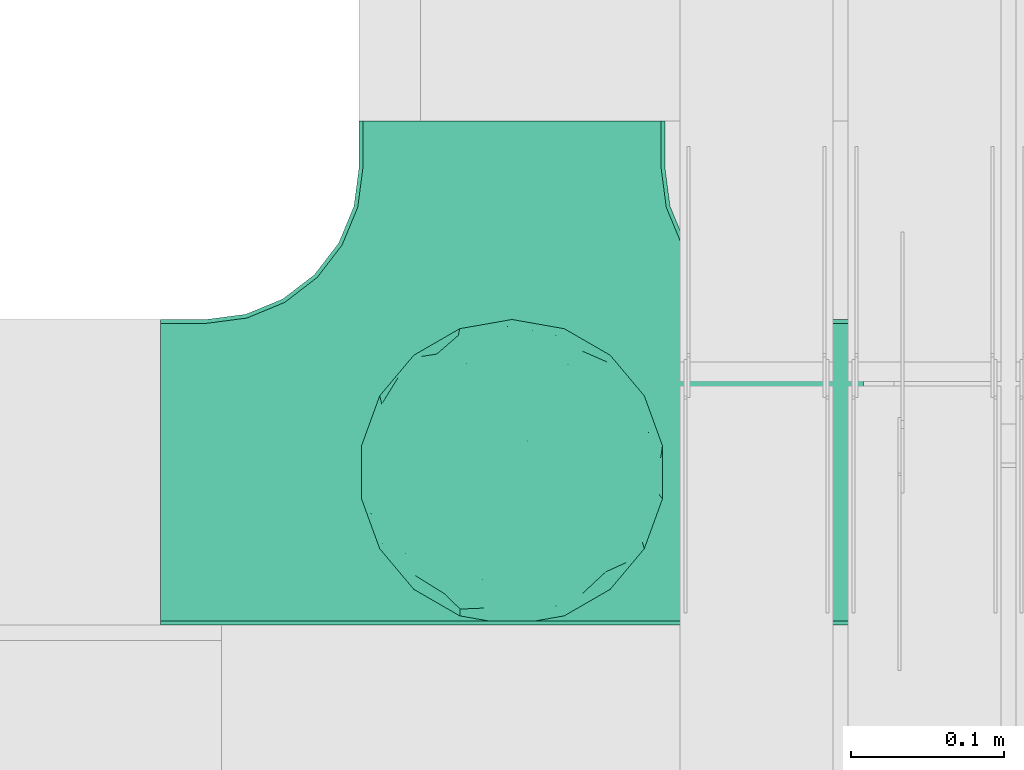
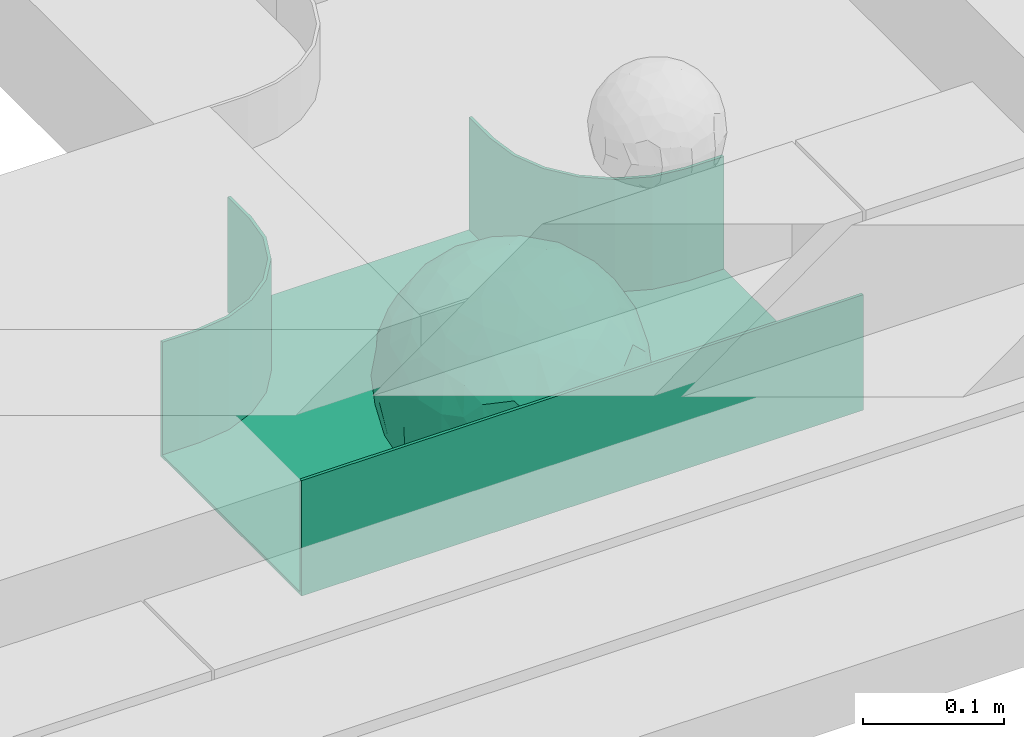
# One storey, part 31 of 32: 1 flow fitting.
"""IFC2X3 building model written with IfcOpenShell, lengths in millimetres."""

from ifc_helpers import new_model, entity, si_unit, converted_unit, derived_unit, direction, frame, origin, place, context, subcontext, project, spatial, faceted_brep, source, transform, mapped, material, material_list, type_object, type_shapes, element, save


model = new_model("IFC2X3")

# Units and contexts
model_context = context("Model", 3, precision=0.01, world=origin(), true_north=direction((6.12303176911189e-17, 1.0)))
body_context = subcontext(model_context, "Body", "Model", "MODEL_VIEW")
ifc_project = project(units=[si_unit("LENGTHUNIT", "METRE", prefix="MILLI"), si_unit("AREAUNIT", "SQUARE_METRE"), si_unit("VOLUMEUNIT", "CUBIC_METRE"), converted_unit("PLANEANGLEUNIT", "DEGREE", entity("IfcRatioMeasure", 0.0174532925199433), si_unit("PLANEANGLEUNIT", "RADIAN"), dimensions=[0, 0, 0, 0, 0, 0, 0]), si_unit("MASSUNIT", "GRAM", prefix="KILO"), derived_unit("MASSDENSITYUNIT", [(si_unit("MASSUNIT", "GRAM", prefix="KILO"), 1), (si_unit("LENGTHUNIT", "METRE"), -3)]), derived_unit("MOMENTOFINERTIAUNIT", [(si_unit("LENGTHUNIT", "METRE"), 4)]), si_unit("TIMEUNIT", "SECOND"), si_unit("FREQUENCYUNIT", "HERTZ"), si_unit("THERMODYNAMICTEMPERATUREUNIT", "DEGREE_CELSIUS"), derived_unit("THERMALTRANSMITTANCEUNIT", [(si_unit("MASSUNIT", "GRAM", prefix="KILO"), 1), (si_unit("THERMODYNAMICTEMPERATUREUNIT", "KELVIN"), -1), (si_unit("TIMEUNIT", "SECOND"), -3)]), derived_unit("VOLUMETRICFLOWRATEUNIT", [(si_unit("LENGTHUNIT", "METRE"), 3), (si_unit("TIMEUNIT", "SECOND"), -1)]), derived_unit("MASSFLOWRATEUNIT", [(si_unit("MASSUNIT", "GRAM", prefix="KILO"), 1), (si_unit("TIMEUNIT", "SECOND"), -1)]), derived_unit("ROTATIONALFREQUENCYUNIT", [(si_unit("TIMEUNIT", "SECOND"), -1)]), si_unit("ELECTRICCURRENTUNIT", "AMPERE"), si_unit("ELECTRICVOLTAGEUNIT", "VOLT"), si_unit("POWERUNIT", "WATT"), si_unit("FORCEUNIT", "NEWTON", prefix="KILO"), si_unit("ILLUMINANCEUNIT", "LUX"), si_unit("LUMINOUSFLUXUNIT", "LUMEN"), si_unit("LUMINOUSINTENSITYUNIT", "CANDELA"), derived_unit("USERDEFINED", [(si_unit("MASSUNIT", "GRAM", prefix="KILO"), -1), (si_unit("LENGTHUNIT", "METRE"), -2), (si_unit("TIMEUNIT", "SECOND"), 3), (si_unit("LUMINOUSFLUXUNIT", "LUMEN"), 1)]), derived_unit("LINEARVELOCITYUNIT", [(si_unit("LENGTHUNIT", "METRE"), 1), (si_unit("TIMEUNIT", "SECOND"), -1)]), si_unit("PRESSUREUNIT", "PASCAL"), derived_unit("USERDEFINED", [(si_unit("LENGTHUNIT", "METRE"), -2), (si_unit("MASSUNIT", "GRAM", prefix="KILO"), 1), (si_unit("TIMEUNIT", "SECOND"), -2)]), derived_unit("LINEARFORCEUNIT", [(si_unit("MASSUNIT", "GRAM", prefix="KILO"), 1), (si_unit("LENGTHUNIT", "METRE"), 1), (si_unit("TIMEUNIT", "SECOND"), -2), (si_unit("LENGTHUNIT", "METRE"), -1)]), derived_unit("PLANARFORCEUNIT", [(si_unit("MASSUNIT", "GRAM", prefix="KILO"), 1), (si_unit("LENGTHUNIT", "METRE"), 1), (si_unit("TIMEUNIT", "SECOND"), -2), (si_unit("LENGTHUNIT", "METRE"), -2)])], contexts=[model_context])

# Site, building, storey
site_placement = place(None, origin())
site = spatial("IfcSite", under=ifc_project, at=site_placement, CompositionType="ELEMENT")
building_placement = place(site_placement, origin())
building = spatial("IfcBuilding", under=site, at=building_placement, CompositionType="ELEMENT")
storey_placement = place(building_placement, frame((0.0, 0.0, 8100.0)))
storey = spatial("IfcBuildingStorey", under=building, at=storey_placement, CompositionType="ELEMENT", Elevation=8100.0)

# Flow fitting
ifc_material_1 = material()
ifc_material_2 = material()
ifc_material_list = material_list([ifc_material_1, ifc_material_2])
cable_carrier_fitting_type = type_object("IfcCableCarrierFittingType", PredefinedType="NOTDEFINED", material=ifc_material_1)
shared_shape = source(origin(), body_context, "Body", "Brep", [
    faceted_brep([(76.48, -37.8, -52.17), (89.29, -26.17, -36.65), (85.27, -46.63, -23.54), (-17.29, -34.78, -92.15), (0.0, -44.16, -89.72), (-24.64, -51.58, -82.05), (76.33, -15.08, -62.82), (55.58, -29.55, -77.71), (-17.1, 96.98, 0.0), (-18.67, 88.89, -41.84), (-33.9, 89.53, -28.9), (-45.46, -10.48, -88.45), (-19.82, 5.04, -97.89), (-23.66, -16.13, -95.81), (92.54, 33.68, 0.0), (85.28, 45.77, -25.16), (86.6, 50.0, 0.0), (49.24, -85.29, 0.0), (62.2, -72.19, -30.32), (64.28, -76.6, 0.0), (97.17, -8.72, -21.95), (90.76, 0.0, -41.98), (96.14, 14.4, -23.44), (98.48, 17.36, 0.0), (98.48, 0.0, 0.0), (79.01, 8.48, -60.71), (76.48, 37.8, -52.17), (87.7, 23.44, -41.95), (29.16, -37.6, -87.95), (20.3, -63.77, -74.31), (-69.62, 53.19, -48.2), (-47.21, 56.75, -67.46), (-61.6, 43.47, -65.69), (29.45, 71.32, -63.61), (47.21, 56.75, -67.46), (30.04, 49.65, -81.44), (-49.67, -77.09, -39.87), (-34.2, -93.97, 0.0), (-49.24, -85.29, 0.0), (61.4, 65.14, -44.57), (74.68, 59.14, -30.41), (61.95, 44.54, -64.64), (28.77, -89.42, -34.29), (34.2, -93.97, 0.0), (25.65, -95.48, 0.0), (17.1, -96.98, 0.0), (-64.28, -76.6, 0.0), (-75.44, -63.3, 0.0), (-74.75, -61.55, -24.99), (7.5, -83.69, -54.22), (36.49, -70.37, -60.97), (-76.48, -37.8, -52.17), (-87.07, -22.49, -43.74), (-79.06, -6.54, -60.88), (63.53, 0.0, -77.22), (-63.53, 0.0, -77.22), (-81.93, 16.04, -55.05), (-98.48, -17.36, 0.0), (-95.57, -17.05, -24.0), (-92.54, -33.68, 0.0), (65.86, 23.41, -71.51), (-19.3, 70.27, -68.49), (-44.33, 79.42, -41.56), (-76.48, 37.8, -52.17), (-45.05, 37.36, -81.09), (-67.2, 22.41, -70.59), (45.89, 15.54, -87.48), (-67.14, -22.46, -70.63), (-97.69, 5.09, -20.78), (-90.76, 0.0, -41.98), (-92.54, 33.68, 0.0), (-92.15, 27.2, -27.72), (28.87, 87.52, -38.83), (7.5, 83.69, -54.22), (1.23, 95.73, -28.9), (3.52, -95.84, -28.34), (-8.55, -98.49, 0.0), (-12.28, -96.15, -24.6), (75.44, 63.3, 0.0), (64.28, 76.6, 0.0), (75.44, -63.3, 0.0), (86.6, -50.0, 0.0), (-75.44, 63.3, 0.0), (-84.89, 46.81, -24.54), (-86.6, 50.0, 0.0), (-65.62, -61.39, -43.88), (-47.21, -56.75, -67.46), (-85.24, -44.68, -27.17), (46.02, 37.17, -80.63), (-63.18, 67.68, -37.79), (-7.15, -67.62, -73.33), (31.54, -5.3, -94.75), (9.85, -20.5, -97.38), (0.0, 13.3, -99.11), (49.35, -11.18, -86.25), (92.54, -33.68, 0.0), (98.48, -17.36, 0.0), (49.24, 85.29, 0.0), (46.4, 79.11, -39.86), (34.2, 93.97, 0.0), (-53.11, 15.12, -83.37), (64.53, -54.17, -53.86), (47.21, -56.75, -67.46), (22.89, 27.57, -93.36), (74.68, -59.14, -30.41), (46.4, -79.11, -39.86), (-15.74, 23.19, -95.99), (2.81, 33.98, -94.01), (9.21, 52.39, -84.68), (9.73, 69.75, -71.0), (17.1, 96.98, 0.0), (-5.62, -90.16, -42.88), (0.0, -100.0, 0.0), (-25.13, -93.37, -25.51), (-25.95, -84.88, -46.06), (-17.1, -96.98, 0.0), (-10.24, -80.78, -58.05), (-31.24, -69.76, -64.48), (-42.19, -33.64, -84.2), (-35.78, 18.55, -91.52), (-61.62, -43.52, -65.64), (-17.34, 40.89, -89.6), (-29.1, 55.69, -77.79), (-10.66, 57.03, -81.45), (-59.77, -75.57, -26.75), (-86.6, -50.0, 0.0), (-98.48, 0.0, 0.0), (-98.48, 17.36, 0.0), (-74.77, 60.7, -26.92), (-64.28, 76.6, 0.0), (-49.24, 85.29, 0.0), (-34.2, 93.97, 0.0), (0.0, 100.0, 0.0), (-76.48, -37.8, 52.17), (-89.29, -26.17, 36.65), (-85.27, -46.63, 23.54), (17.29, -34.78, 92.15), (0.0, -44.16, 89.72), (24.64, -51.58, 82.05), (-76.33, -15.08, 62.82), (-55.58, -29.55, 77.71), (18.67, 88.89, 41.84), (33.9, 89.53, 28.9), (17.34, 40.89, 89.6), (15.74, 23.19, 95.99), (35.78, 18.55, 91.52), (-85.28, 45.77, 25.16), (-62.2, -72.19, 30.32), (-97.17, -8.72, 21.95), (-96.14, 14.4, 23.44), (-79.01, 8.48, 60.71), (-76.48, 37.8, 52.17), (-87.7, 23.44, 41.95), (-29.16, -37.6, 87.95), (-20.3, -63.77, 74.31), (69.62, 53.19, 48.2), (47.21, 56.75, 67.46), (61.6, 43.47, 65.69), (-61.4, 65.14, 44.57), (49.27, -77.35, 39.88), (-74.68, 59.14, 30.41), (-61.95, 44.54, 64.64), (-7.5, -83.69, 54.22), (-36.49, -70.37, 60.97), (-28.77, -89.42, 34.29), (74.74, -61.65, 24.74), (3.0, -95.52, 29.45), (-13.47, -92.75, 34.88), (76.48, -37.8, 52.17), (87.07, -22.49, 43.74), (79.06, -6.54, 60.88), (-63.53, 0.0, 77.22), (63.53, 0.0, 77.22), (81.93, 16.04, 55.05), (95.57, -17.05, 24.0), (-65.86, 23.41, 71.51), (19.3, 70.27, 68.49), (44.33, 79.42, 41.56), (76.48, 37.8, 52.17), (45.05, 37.36, 81.09), (67.2, 22.41, 70.59), (-45.89, 15.54, 87.48), (67.14, -22.46, 70.63), (97.69, 5.09, 20.78), (90.76, 0.0, 41.98), (92.15, 27.2, 27.72), (-28.87, 87.52, 38.83), (-7.5, 83.69, 54.22), (-1.23, 95.73, 28.9), (7.15, -67.62, 73.33), (30.04, -71.02, 63.66), (-90.76, 0.0, 41.98), (84.89, 46.81, 24.54), (65.66, -61.85, 43.17), (47.21, -56.75, 67.46), (85.24, -44.68, 27.17), (-30.04, 49.65, 81.44), (-47.21, 56.75, 67.46), (-46.02, 37.17, 80.63), (63.18, 67.68, 37.79), (-31.54, -5.3, 94.75), (-9.85, -20.5, 97.38), (0.0, 13.3, 99.11), (-49.35, -11.18, 86.25), (-46.4, 79.11, 39.86), (-29.45, 71.32, 63.61), (24.31, -93.79, 24.74), (-64.53, -54.17, 53.86), (-47.21, -56.75, 67.46), (-22.89, 27.57, 93.36), (-46.4, -79.11, 39.86), (-74.68, -59.14, 30.41), (19.82, 5.04, 97.89), (-2.81, 33.98, 94.01), (-9.21, 52.39, 84.68), (-9.73, 69.75, 71.0), (9.65, -80.54, 58.49), (23.47, -86.31, 44.72), (35.11, -89.62, 27.11), (42.19, -33.64, 84.2), (23.66, -16.13, 95.81), (45.46, -10.48, 88.45), (61.62, -43.52, 65.64), (29.1, 55.69, 77.79), (10.66, 57.03, 81.45), (59.35, -75.82, 26.99), (74.77, 60.7, 26.92), (53.11, 15.12, 83.37)], [[[0, 1, 2]], [[3, 4, 5]], [[6, 0, 7]], [[8, 9, 10]], [[11, 12, 13]], [[14, 15, 16]], [[17, 18, 19]], [[20, 21, 22]], [[22, 23, 24]], [[25, 26, 27]], [[4, 28, 29]], [[30, 31, 32]], [[33, 34, 35]], [[36, 37, 38]], [[39, 40, 41]], [[42, 43, 44, 45]], [[46, 47, 48]], [[49, 50, 42]], [[51, 52, 53]], [[54, 25, 6]], [[55, 53, 56]], [[57, 58, 59]], [[26, 25, 60]], [[61, 31, 62]], [[32, 63, 30]], [[64, 65, 32]], [[54, 66, 60]], [[53, 67, 51]], [[58, 68, 69]], [[68, 70, 71]], [[72, 73, 74]], [[75, 76, 77]], [[6, 7, 54]], [[24, 20, 22]], [[78, 40, 79]], [[15, 26, 40]], [[1, 21, 20]], [[80, 2, 81]], [[63, 56, 71]], [[82, 83, 84]], [[36, 85, 86]], [[87, 58, 52]], [[35, 34, 88]], [[62, 31, 89]], [[42, 75, 49]], [[4, 29, 90]], [[91, 92, 93]], [[7, 94, 54]], [[6, 1, 0]], [[95, 81, 2]], [[24, 96, 20]], [[1, 20, 95]], [[1, 95, 2]], [[27, 22, 21]], [[15, 14, 22]], [[25, 27, 21]], [[15, 78, 16]], [[41, 40, 26]], [[40, 78, 15]], [[39, 97, 79]], [[97, 98, 99]], [[40, 39, 79]], [[33, 73, 72]], [[21, 1, 6]], [[25, 54, 60]], [[64, 100, 65]], [[26, 15, 27]], [[6, 25, 21]], [[0, 101, 7]], [[102, 28, 7]], [[92, 91, 28]], [[94, 28, 91]], [[88, 34, 41]], [[54, 94, 66]], [[41, 26, 60]], [[103, 91, 93]], [[88, 41, 60]], [[20, 96, 95]], [[101, 18, 102]], [[104, 80, 19]], [[101, 0, 104]], [[18, 105, 102]], [[43, 42, 105]], [[17, 43, 105]], [[29, 28, 102]], [[28, 4, 92]], [[105, 50, 102]], [[90, 29, 49]], [[88, 60, 66]], [[41, 34, 39]], [[34, 98, 39]], [[97, 39, 98]], [[103, 66, 91]], [[88, 66, 103]], [[12, 106, 93]], [[33, 98, 34]], [[107, 103, 93]], [[35, 103, 108]], [[103, 35, 88]], [[33, 109, 73]], [[109, 35, 108]], [[110, 72, 74]], [[72, 110, 99]], [[98, 33, 72]], [[99, 98, 72]], [[80, 104, 2]], [[0, 2, 104]], [[101, 104, 18]], [[7, 101, 102]], [[19, 18, 104]], [[105, 18, 17]], [[77, 111, 75]], [[75, 45, 112]], [[113, 114, 111]], [[115, 77, 76]], [[36, 114, 37]], [[90, 5, 4]], [[75, 42, 45]], [[50, 49, 29]], [[49, 116, 90]], [[5, 117, 86]], [[90, 116, 117]], [[118, 13, 3]], [[118, 5, 86]], [[11, 119, 12]], [[67, 120, 51]], [[11, 13, 118]], [[65, 55, 56]], [[121, 122, 123]], [[90, 117, 5]], [[51, 120, 85]], [[117, 36, 86]], [[36, 117, 114]], [[46, 48, 124]], [[38, 124, 36]], [[85, 124, 48]], [[87, 125, 59]], [[125, 87, 47]], [[48, 51, 85]], [[68, 57, 126, 127]], [[59, 58, 87]], [[58, 69, 52]], [[53, 52, 69]], [[87, 52, 51]], [[56, 53, 69]], [[53, 55, 67]], [[71, 56, 69]], [[56, 63, 65]], [[71, 69, 68]], [[128, 129, 89]], [[11, 67, 55]], [[120, 118, 86]], [[32, 65, 63]], [[100, 55, 65]], [[118, 120, 67]], [[85, 120, 86]], [[129, 128, 82]], [[64, 32, 31]], [[62, 130, 131]], [[130, 62, 89]], [[9, 73, 61]], [[10, 62, 131]], [[109, 61, 73]], [[73, 9, 74]], [[64, 121, 119]], [[122, 61, 123]], [[64, 119, 100]], [[64, 31, 122]], [[107, 108, 103]], [[47, 87, 48]], [[51, 48, 87]], [[57, 68, 58]], [[64, 122, 121]], [[89, 129, 130]], [[67, 11, 118]], [[11, 55, 100]], [[82, 128, 83]], [[30, 128, 89]], [[83, 63, 71]], [[63, 83, 128]], [[84, 83, 71]], [[10, 61, 62]], [[74, 8, 132]], [[8, 74, 9]], [[110, 74, 132]], [[3, 92, 4]], [[92, 13, 12]], [[22, 27, 15]], [[14, 23, 22]], [[11, 100, 119]], [[128, 30, 63]], [[31, 30, 89]], [[28, 94, 7]], [[66, 94, 91]], [[42, 50, 105]], [[29, 102, 50]], [[106, 107, 93]], [[123, 107, 121]], [[35, 109, 33]], [[109, 108, 123]], [[75, 112, 76]], [[113, 77, 115]], [[114, 116, 111]], [[115, 37, 113]], [[37, 114, 113]], [[49, 75, 111]], [[117, 116, 114]], [[111, 77, 113]], [[49, 111, 116]], [[118, 3, 5]], [[92, 3, 13]], [[106, 119, 121]], [[92, 12, 93]], [[119, 106, 12]], [[107, 106, 121]], [[46, 124, 38]], [[85, 36, 124]], [[70, 68, 127]], [[70, 84, 71]], [[31, 61, 122]], [[109, 123, 61]], [[107, 123, 108]], [[8, 10, 131]], [[61, 10, 9]], [[133, 134, 135]], [[136, 137, 138]], [[139, 133, 140]], [[110, 141, 142]], [[143, 144, 145]], [[70, 146, 84]], [[38, 147, 46]], [[126, 57, 148]], [[149, 127, 126]], [[150, 151, 152]], [[137, 153, 154]], [[155, 156, 157]], [[130, 129, 158]], [[159, 43, 17]], [[158, 160, 161]], [[162, 163, 164]], [[19, 80, 165]], [[166, 167, 115]], [[168, 169, 170]], [[171, 150, 139]], [[172, 170, 173]], [[96, 174, 95]], [[151, 150, 175]], [[176, 156, 177]], [[157, 178, 155]], [[179, 180, 157]], [[171, 181, 175]], [[170, 182, 168]], [[174, 183, 184]], [[185, 23, 14, 16]], [[186, 187, 188]], [[138, 189, 190]], [[139, 140, 171]], [[126, 148, 149]], [[82, 160, 129]], [[146, 151, 160]], [[134, 191, 148]], [[47, 135, 125]], [[178, 173, 185]], [[78, 192, 16]], [[159, 193, 194]], [[195, 174, 169]], [[196, 197, 198]], [[177, 156, 199]], [[166, 112, 45]], [[154, 189, 137]], [[200, 201, 202]], [[140, 203, 171]], [[191, 149, 148]], [[59, 125, 135]], [[133, 139, 134]], [[134, 148, 59]], [[134, 59, 135]], [[152, 149, 191]], [[146, 70, 149]], [[150, 152, 191]], [[146, 82, 84]], [[161, 160, 151]], [[160, 82, 146]], [[204, 131, 130]], [[186, 205, 187]], [[160, 158, 129]], [[197, 196, 205]], [[191, 134, 139]], [[150, 171, 175]], [[45, 206, 166]], [[151, 146, 152]], [[139, 150, 191]], [[133, 207, 140]], [[208, 153, 140]], [[201, 200, 153]], [[203, 153, 200]], [[198, 197, 161]], [[171, 203, 181]], [[161, 151, 175]], [[209, 200, 202]], [[198, 161, 175]], [[148, 57, 59]], [[38, 37, 210]], [[211, 47, 46]], [[207, 133, 211]], [[147, 210, 208]], [[210, 37, 164]], [[208, 207, 147]], [[154, 153, 208]], [[153, 137, 201]], [[210, 163, 208]], [[189, 154, 162]], [[198, 175, 181]], [[161, 197, 158]], [[197, 204, 158]], [[130, 158, 204]], [[209, 181, 200]], [[198, 181, 209]], [[212, 144, 202]], [[205, 204, 197]], [[213, 209, 202]], [[196, 209, 214]], [[209, 196, 198]], [[205, 215, 187]], [[215, 196, 214]], [[8, 186, 188]], [[186, 8, 131]], [[204, 205, 186]], [[131, 204, 186]], [[47, 211, 135]], [[133, 135, 211]], [[207, 211, 147]], [[140, 207, 208]], [[46, 147, 211]], [[210, 147, 38]], [[166, 115, 76, 112]], [[115, 164, 37]], [[163, 162, 154]], [[216, 166, 217]], [[138, 137, 189]], [[162, 216, 189]], [[218, 44, 43]], [[44, 218, 206]], [[189, 216, 190]], [[219, 220, 136]], [[219, 138, 194]], [[221, 145, 212]], [[182, 222, 168]], [[221, 220, 219]], [[180, 172, 173]], [[143, 223, 224]], [[168, 222, 193]], [[194, 138, 190]], [[190, 159, 194]], [[190, 217, 218]], [[19, 165, 225]], [[17, 225, 159]], [[193, 225, 165]], [[195, 81, 95]], [[81, 195, 80]], [[165, 168, 193]], [[183, 96, 24, 23]], [[95, 174, 195]], [[174, 184, 169]], [[170, 169, 184]], [[195, 169, 168]], [[173, 170, 184]], [[170, 172, 182]], [[185, 173, 184]], [[173, 178, 180]], [[185, 184, 183]], [[226, 79, 199]], [[221, 182, 172]], [[222, 219, 194]], [[157, 180, 178]], [[227, 172, 180]], [[219, 222, 182]], [[193, 222, 194]], [[79, 226, 78]], [[179, 157, 156]], [[177, 97, 99]], [[97, 177, 199]], [[141, 187, 176]], [[142, 177, 99]], [[215, 176, 187]], [[187, 141, 188]], [[179, 143, 145]], [[223, 176, 224]], [[179, 145, 227]], [[179, 156, 223]], [[213, 214, 209]], [[96, 183, 174]], [[185, 183, 23]], [[80, 195, 165]], [[168, 165, 195]], [[199, 79, 97]], [[182, 221, 219]], [[221, 172, 227]], [[78, 226, 192]], [[155, 226, 199]], [[192, 178, 185]], [[178, 192, 226]], [[16, 192, 185]], [[142, 176, 177]], [[188, 110, 132]], [[110, 188, 141]], [[8, 188, 132]], [[136, 201, 137]], [[201, 220, 212]], [[149, 152, 146]], [[70, 127, 149]], [[167, 162, 164]], [[179, 227, 180]], [[221, 227, 145]], [[226, 155, 178]], [[156, 155, 199]], [[153, 203, 140]], [[181, 203, 200]], [[164, 163, 210]], [[154, 208, 163]], [[144, 213, 202]], [[224, 213, 143]], [[196, 215, 205]], [[215, 214, 224]], [[166, 216, 162]], [[190, 216, 217]], [[218, 217, 206]], [[43, 159, 218]], [[190, 218, 159]], [[166, 206, 217]], [[44, 206, 45]], [[219, 136, 138]], [[201, 136, 220]], [[201, 212, 202]], [[221, 212, 220]], [[145, 144, 212]], [[213, 144, 143]], [[19, 225, 17]], [[193, 159, 225]], [[179, 223, 143]], [[156, 176, 223]], [[215, 224, 176]], [[213, 224, 214]], [[110, 142, 99]], [[176, 142, 141]], [[115, 167, 164]], [[166, 162, 167]]]),
    faceted_brep([(-103.41, -174.12, 50.0), (-100.0, -200.0, 50.0), (-100.0, -230.0, 50.0), (-97.46, -230.0, 50.0), (-97.46, -200.0, 50.0), (-100.95, -173.46, 50.0), (-111.2, -148.73, 50.0), (-127.49, -127.49, 50.0), (-148.73, -111.2, 50.0), (-173.46, -100.95, 50.0), (-200.0, -97.46, 50.0), (-230.0, -97.46, 50.0), (-230.0, -100.0, 50.0), (-200.0, -100.0, 50.0), (-174.12, -103.41, 50.0), (-150.0, -113.4, 50.0), (-129.29, -129.29, 50.0), (-113.4, -150.0, 50.0), (230.0, -100.0, 50.0), (230.0, -97.46, 50.0), (200.0, -97.46, 50.0), (173.46, -100.95, 50.0), (148.73, -111.2, 50.0), (127.49, -127.49, 50.0), (111.2, -148.73, 50.0), (100.95, -173.46, 50.0), (97.46, -200.0, 50.0), (97.46, -230.0, 50.0), (100.0, -230.0, 50.0), (100.0, -200.0, 50.0), (103.41, -174.12, 50.0), (113.4, -150.0, 50.0), (129.29, -129.29, 50.0), (150.0, -113.4, 50.0), (174.12, -103.41, 50.0), (200.0, -100.0, 50.0), (230.0, 97.46, 50.0), (230.0, 100.0, 50.0), (-230.0, 100.0, 50.0), (-230.0, 97.46, 50.0), (-230.0, -100.0, -50.0), (-230.0, 100.0, -50.0), (230.0, 100.0, -50.0), (230.0, -100.0, -50.0), (200.0, -100.0, -50.0), (174.12, -103.41, -50.0), (150.0, -113.4, -50.0), (129.29, -129.29, -50.0), (113.4, -150.0, -50.0), (103.41, -174.12, -50.0), (100.0, -200.0, -50.0), (100.0, -230.0, -50.0), (-100.0, -230.0, -50.0), (-100.0, -200.0, -50.0), (-103.41, -174.12, -50.0), (-113.4, -150.0, -50.0), (-129.29, -129.29, -50.0), (-150.0, -113.4, -50.0), (-174.12, -103.41, -50.0), (-200.0, -100.0, -50.0), (-100.0, -200.0, -47.46), (97.46, -230.0, -47.46), (-97.46, -230.0, -47.46), (-97.46, -200.0, -47.46), (-200.0, -97.46, -47.46), (-230.0, -97.46, -47.46), (230.0, -97.46, -47.46), (200.0, -97.46, -47.46), (-230.0, 97.46, -47.46), (-200.0, -100.0, -47.46), (200.0, -100.0, -47.46), (230.0, 97.46, -47.46), (97.46, -200.0, -47.46), (100.0, -200.0, -47.46), (-173.46, -100.95, -47.46), (-148.73, -111.2, -47.46), (-127.49, -127.49, -47.46), (-111.2, -148.73, -47.46), (-100.95, -173.46, -47.46), (100.95, -173.46, -47.46), (111.2, -148.73, -47.46), (127.49, -127.49, -47.46), (148.73, -111.2, -47.46), (173.46, -100.95, -47.46)], [[[0, 1, 2, 3, 4, 5, 6, 7, 8, 9, 10, 11, 12, 13, 14, 15, 16, 17]], [[18, 19, 20, 21, 22, 23, 24, 25, 26, 27, 28, 29, 30, 31, 32, 33, 34, 35]], [[36, 37, 38, 39]], [[40, 41, 42, 43, 44, 45, 46, 47, 48, 49, 50, 51, 52, 53, 54, 55, 56, 57, 58, 59]], [[2, 1, 60, 53, 52]], [[3, 2, 52, 51, 28, 27, 61, 62]], [[4, 3, 62, 63]], [[11, 10, 64, 65]], [[20, 19, 66, 67]], [[39, 38, 41, 40, 12, 11, 65, 68]], [[13, 12, 40, 59, 69]], [[18, 35, 70, 44, 43]], [[19, 18, 43, 42, 37, 36, 71, 66]], [[27, 26, 72, 61]], [[29, 28, 51, 50, 73]], [[38, 37, 42, 41]], [[36, 39, 68, 71]], [[68, 65, 64, 74, 75, 76, 77, 78, 63, 62, 61, 72, 79, 80, 81, 82, 83, 67, 66, 71]], [[14, 13, 69, 59, 58]], [[15, 14, 58, 57]], [[57, 56, 16, 15]], [[17, 16, 56, 55]], [[0, 17, 55, 54]], [[1, 0, 54, 53, 60]], [[5, 78, 77, 6]], [[6, 77, 76, 7]], [[63, 78, 5, 4]], [[8, 75, 74, 9]], [[9, 74, 64, 10]], [[7, 76, 75, 8]], [[21, 83, 82, 22]], [[22, 82, 81, 23]], [[67, 83, 21, 20]], [[24, 80, 79, 25]], [[25, 79, 72, 26]], [[23, 81, 80, 24]], [[30, 29, 73, 50, 49]], [[31, 30, 49, 48]], [[32, 31, 48, 47]], [[34, 33, 46, 45]], [[34, 45, 44, 70, 35]], [[46, 33, 32, 47]]]),
])
type_shapes(cable_carrier_fitting_type, [shared_shape])
flow_fitting_placement = place(storey_placement, frame((60360.11, 9069.98, 2599.84), z_axis=(0.0, 0.0, 1.0), x_axis=(-1.0, 0.0, 0.0)))
element("IfcFlowFitting", 1, at=flow_fitting_placement, inside=storey, type_object=cable_carrier_fitting_type, material=ifc_material_list, Name="470_DKC_S5_T", context=body_context, shape_type="MappedRepresentation", body=[
    mapped(shared_shape, transform((0.0, 0.0, 0.0), scale=1.0)),
])

save(model, "model.ifc")
